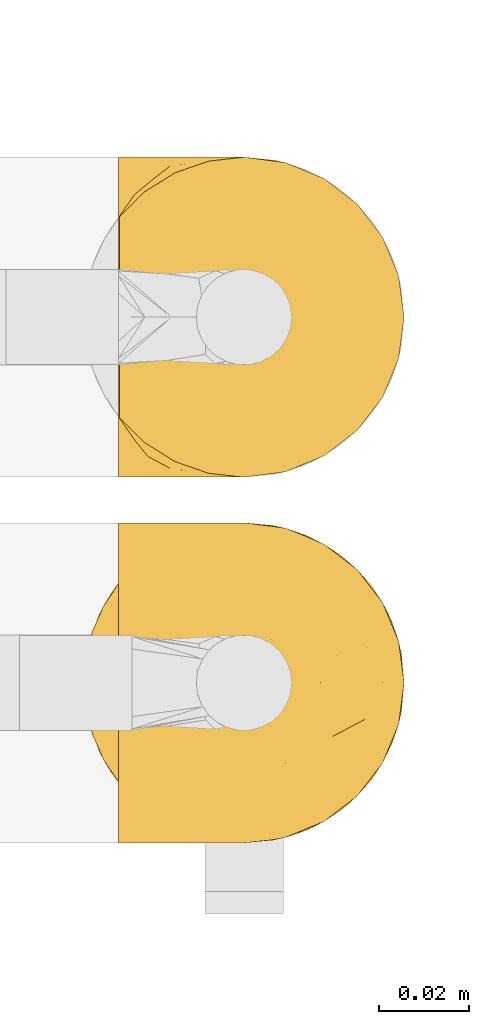
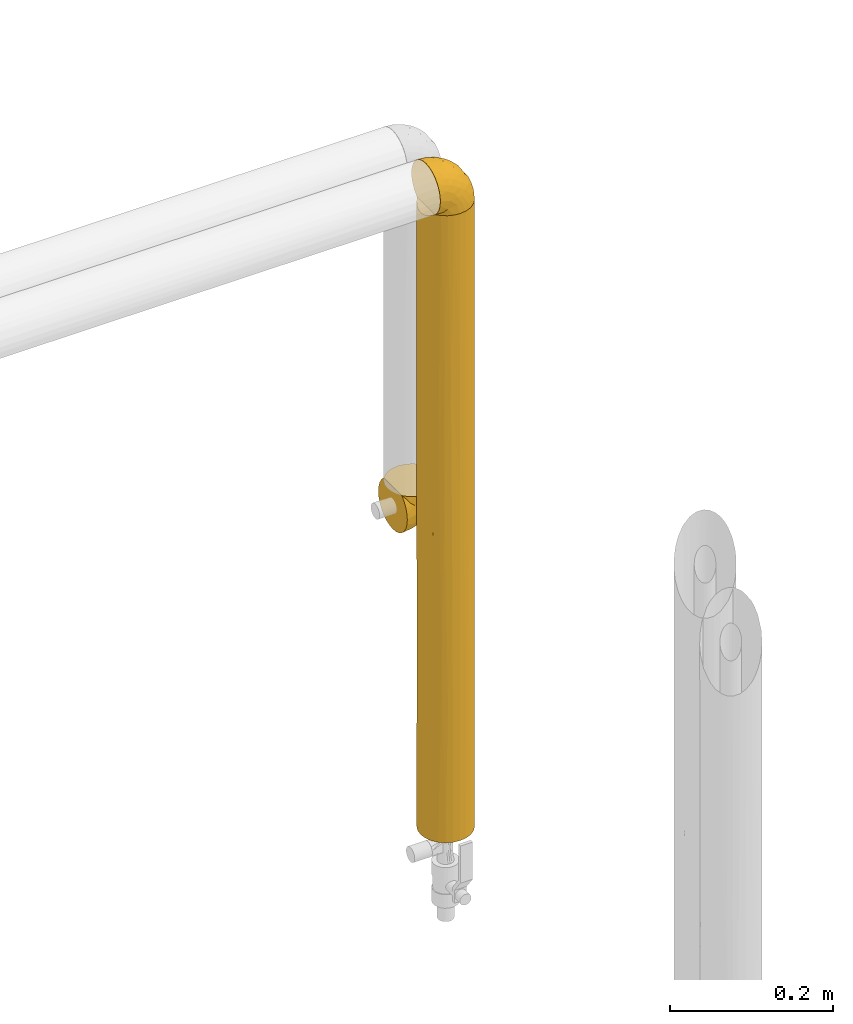
# One storey, part 94 of 827: 3 coverings.
"""IFC2X3 building model written with IfcOpenShell, lengths in millimetres."""

from ifc_helpers import new_model, entity, si_unit, converted_unit, derived_unit, direction, frame, origin, place, context, subcontext, project, spatial, faceted_brep, element, save


model = new_model("IFC2X3")

# Units and contexts
model_context = context("Model", 3, precision=0.01, world=origin(), true_north=direction((6.12303176911189e-17, 1.0)))
body_context = subcontext(model_context, "Body", "Model", "MODEL_VIEW")
ifc_project = project(units=[si_unit("LENGTHUNIT", "METRE", prefix="MILLI"), si_unit("AREAUNIT", "SQUARE_METRE"), si_unit("VOLUMEUNIT", "CUBIC_METRE"), converted_unit("PLANEANGLEUNIT", "DEGREE", entity("IfcRatioMeasure", 0.0174532925199433), si_unit("PLANEANGLEUNIT", "RADIAN"), dimensions=[0, 0, 0, 0, 0, 0, 0]), si_unit("MASSUNIT", "GRAM", prefix="KILO"), derived_unit("MASSDENSITYUNIT", [(si_unit("MASSUNIT", "GRAM", prefix="KILO"), 1), (si_unit("LENGTHUNIT", "METRE"), -3)]), derived_unit("MOMENTOFINERTIAUNIT", [(si_unit("LENGTHUNIT", "METRE"), 4)]), si_unit("TIMEUNIT", "SECOND"), si_unit("FREQUENCYUNIT", "HERTZ"), si_unit("THERMODYNAMICTEMPERATUREUNIT", "DEGREE_CELSIUS"), derived_unit("THERMALTRANSMITTANCEUNIT", [(si_unit("MASSUNIT", "GRAM", prefix="KILO"), 1), (si_unit("THERMODYNAMICTEMPERATUREUNIT", "KELVIN"), -1), (si_unit("TIMEUNIT", "SECOND"), -3)]), derived_unit("VOLUMETRICFLOWRATEUNIT", [(si_unit("LENGTHUNIT", "METRE"), 3), (si_unit("TIMEUNIT", "SECOND"), -1)]), derived_unit("MASSFLOWRATEUNIT", [(si_unit("MASSUNIT", "GRAM", prefix="KILO"), 1), (si_unit("TIMEUNIT", "SECOND"), -1)]), derived_unit("ROTATIONALFREQUENCYUNIT", [(si_unit("TIMEUNIT", "SECOND"), -1)]), si_unit("ELECTRICCURRENTUNIT", "AMPERE"), si_unit("ELECTRICVOLTAGEUNIT", "VOLT"), si_unit("POWERUNIT", "WATT"), si_unit("FORCEUNIT", "NEWTON", prefix="KILO"), si_unit("ILLUMINANCEUNIT", "LUX"), si_unit("LUMINOUSFLUXUNIT", "LUMEN"), si_unit("LUMINOUSINTENSITYUNIT", "CANDELA"), derived_unit("USERDEFINED", [(si_unit("MASSUNIT", "GRAM", prefix="KILO"), -1), (si_unit("LENGTHUNIT", "METRE"), -2), (si_unit("TIMEUNIT", "SECOND"), 3), (si_unit("LUMINOUSFLUXUNIT", "LUMEN"), 1)]), derived_unit("LINEARVELOCITYUNIT", [(si_unit("LENGTHUNIT", "METRE"), 1), (si_unit("TIMEUNIT", "SECOND"), -1)]), si_unit("PRESSUREUNIT", "PASCAL"), derived_unit("USERDEFINED", [(si_unit("LENGTHUNIT", "METRE"), -2), (si_unit("MASSUNIT", "GRAM", prefix="KILO"), 1), (si_unit("TIMEUNIT", "SECOND"), -2)]), derived_unit("LINEARFORCEUNIT", [(si_unit("MASSUNIT", "GRAM", prefix="KILO"), 1), (si_unit("LENGTHUNIT", "METRE"), 1), (si_unit("TIMEUNIT", "SECOND"), -2), (si_unit("LENGTHUNIT", "METRE"), -1)]), derived_unit("PLANARFORCEUNIT", [(si_unit("MASSUNIT", "GRAM", prefix="KILO"), 1), (si_unit("LENGTHUNIT", "METRE"), 1), (si_unit("TIMEUNIT", "SECOND"), -2), (si_unit("LENGTHUNIT", "METRE"), -2)])], contexts=[model_context])

# Site, building, storey
site_placement = place(None, origin())
site = spatial("IfcSite", under=ifc_project, at=site_placement, CompositionType="ELEMENT")
building_placement = place(site_placement, origin())
building = spatial("IfcBuilding", under=site, at=building_placement, CompositionType="ELEMENT")
storey_placement = place(building_placement, frame((0.0, 0.0, 28200.0)))
storey = spatial("IfcBuildingStorey", under=building, at=storey_placement, Name="08", CompositionType="ELEMENT", Elevation=28200.0)

# Coverings
covering_1_placement = place(storey_placement, frame((18854.98, 12899.2, 1335.46)))
element("IfcCovering", 1, at=covering_1_placement, inside=storey, Name=":ADSK_", ObjectType=":ADSK_", PredefinedType="INSULATION", context=body_context, shape_type="Brep", body=[
    faceted_brep([(1.6, 69.36, 21.77), (1.6, 65.11, 15.01), (1.6, 59.47, 9.37), (1.6, 52.71, 5.12), (1.6, 45.17, 2.49), (1.6, 37.25, 1.6), (1.6, 29.31, 2.49), (1.6, 21.77, 5.13), (1.6, 15.01, 9.38), (1.6, 9.37, 15.02), (1.6, 5.12, 21.78), (1.6, 2.49, 29.32), (1.6, 1.6, 37.25), (1.6, 2.48, 45.15), (1.6, 5.1, 52.65), (1.6, 9.31, 59.39), (1.6, 14.9, 65.02), (1.6, 16.96, 65.02), (1.6, 18.43, 65.02), (1.6, 20.19, 65.02), (1.6, 21.96, 65.02), (1.6, 23.72, 65.02), (1.6, 25.49, 65.02), (1.6, 27.25, 65.02), (1.6, 29.02, 65.02), (1.6, 30.78, 65.02), (1.6, 32.55, 65.02), (1.6, 34.31, 65.02), (1.6, 36.08, 65.02), (1.6, 37.84, 65.02), (1.6, 39.61, 65.02), (1.6, 41.37, 65.02), (1.6, 43.14, 65.02), (1.6, 45.19, 65.02), (1.6, 47.25, 65.02), (1.6, 49.31, 65.02), (1.6, 51.36, 65.02), (1.6, 53.42, 65.02), (1.6, 55.48, 65.02), (1.6, 57.53, 65.02), (1.6, 59.59, 65.02), (1.6, 65.19, 59.38), (1.6, 69.4, 52.64), (1.6, 72.01, 45.13), (1.6, 72.9, 37.25), (1.6, 72.0, 29.31), (1.82, 14.9, 65.25), (7.46, 9.3, 65.25), (14.2, 5.09, 65.25), (21.7, 2.48, 65.25), (29.6, 1.6, 65.25), (38.82, 2.81, 65.25), (47.42, 6.37, 65.25), (54.8, 12.04, 65.25), (60.47, 19.42, 65.25), (64.03, 28.02, 65.25), (65.25, 37.25, 65.25), (64.03, 46.47, 65.25), (60.47, 55.07, 65.25), (54.8, 62.45, 65.25), (47.42, 68.12, 65.25), (38.82, 71.68, 65.25), (29.6, 72.9, 65.25), (21.7, 72.01, 65.25), (14.2, 69.4, 65.25), (7.46, 65.19, 65.25), (1.82, 59.59, 65.25), (1.82, 58.56, 65.25), (1.82, 56.8, 65.25), (1.82, 55.4, 65.25), (1.82, 54.0, 65.25), (1.82, 52.61, 65.25), (1.82, 51.21, 65.25), (1.82, 49.81, 65.25), (1.82, 48.42, 65.25), (1.82, 47.02, 65.25), (1.82, 45.62, 65.25), (1.82, 44.23, 65.25), (1.82, 42.83, 65.25), (1.82, 41.43, 65.25), (1.82, 40.04, 65.25), (1.82, 38.64, 65.25), (1.82, 37.25, 65.25), (1.82, 35.48, 65.25), (1.82, 33.72, 65.25), (1.82, 31.95, 65.25), (1.82, 30.19, 65.25), (1.82, 28.42, 65.25), (1.82, 26.66, 65.25), (1.82, 24.89, 65.25), (1.82, 23.13, 65.25), (1.82, 21.07, 65.25), (1.82, 19.01, 65.25), (1.82, 16.96, 65.25), (1.75, 50.36, 65.08), (1.76, 51.91, 65.09), (1.76, 27.73, 65.09), (1.76, 29.06, 65.1), (1.74, 23.0, 65.08), (1.76, 39.29, 65.09), (1.75, 16.3, 65.09), (1.75, 17.69, 65.09), (1.75, 42.09, 65.09), (1.76, 43.53, 65.1), (1.74, 58.23, 65.08), (1.75, 59.59, 65.09), (1.74, 46.32, 65.08), (1.76, 47.68, 65.09), (1.75, 19.0, 65.08), (1.75, 30.39, 65.09), (1.74, 31.67, 65.07), (1.76, 37.94, 65.1), (1.76, 36.57, 65.09), (1.76, 45.01, 65.1), (1.73, 35.19, 65.07), (1.74, 26.37, 65.07), (1.75, 25.1, 65.09), (1.74, 56.91, 65.08), (1.75, 40.68, 65.09), (1.78, 32.77, 65.13), (1.76, 20.34, 65.1), (1.76, 21.67, 65.09), (1.75, 33.92, 65.09), (1.76, 53.39, 65.1), (1.75, 54.7, 65.09), (1.75, 14.9, 65.09), (1.76, 49.03, 65.09), (13.11, 3.58, 53.74), (8.18, 6.24, 57.19), (25.84, 1.6, 51.25), (28.13, 1.6, 59.77), (15.6, 1.6, 41.0), (5.2, 9.92, 61.64), (20.72, 1.6, 46.12), (7.07, 1.6, 38.71), (35.56, 27.59, 13.0), (16.98, 25.47, 5.55), (25.95, 37.25, 6.44), (35.4, 2.33, 55.39), (32.74, 2.37, 48.48), (43.51, 8.53, 39.63), (53.51, 15.54, 43.5), (49.6, 8.96, 52.38), (40.07, 4.31, 49.31), (42.61, 4.31, 58.01), (20.45, 7.06, 22.23), (10.52, 7.06, 19.14), (14.87, 12.03, 13.73), (24.92, 2.3, 39.1), (34.61, 21.13, 15.38), (61.84, 30.63, 46.7), (60.43, 23.6, 49.4), (14.29, 37.25, 4.12), (57.0, 15.54, 55.35), (42.79, 18.65, 23.83), (33.34, 15.3, 19.0), (21.53, 3.14, 32.44), (11.52, 3.59, 26.73), (12.66, 18.27, 8.12), (34.11, 7.07, 31.34), (32.29, 3.86, 38.81), (24.41, 13.04, 16.11), (24.95, 18.27, 11.96), (44.19, 26.27, 20.31), (56.24, 23.06, 38.81), (56.83, 29.25, 35.48), (50.94, 24.41, 28.94), (50.38, 31.04, 25.21), (46.6, 37.25, 20.24), (36.28, 37.25, 13.34), (62.72, 37.25, 52.55), (47.39, 15.08, 33.16), (38.92, 12.03, 27.33), (29.55, 9.82, 22.86), (26.82, 6.14, 27.48), (60.4, 37.25, 40.89), (53.5, 37.25, 30.56), (41.8, 70.18, 54.41), (61.8, 44.04, 46.71), (49.33, 49.17, 26.31), (35.54, 46.9, 12.98), (14.87, 62.45, 13.72), (12.65, 56.21, 8.12), (47.44, 65.53, 46.04), (56.06, 58.95, 51.06), (50.17, 58.17, 35.69), (20.44, 67.43, 22.22), (10.52, 67.43, 19.13), (11.52, 70.89, 26.72), (38.79, 55.13, 19.65), (33.87, 72.21, 51.87), (25.84, 72.9, 51.25), (27.72, 72.9, 58.25), (7.07, 72.9, 38.71), (62.13, 49.42, 54.36), (50.52, 65.53, 56.5), (56.47, 45.41, 34.9), (58.39, 50.89, 43.16), (16.98, 49.01, 5.54), (39.3, 66.8, 35.66), (38.56, 70.39, 47.21), (24.94, 56.21, 11.95), (30.34, 72.31, 46.27), (26.49, 72.1, 39.95), (15.6, 72.9, 41.0), (20.72, 72.9, 46.12), (26.6, 62.45, 18.27), (21.54, 71.35, 32.43), (35.7, 72.26, 58.69), (38.91, 62.45, 27.31), (30.65, 67.99, 29.52), (44.9, 62.85, 35.02), (34.09, 70.57, 40.81), (13.11, 70.91, 53.74), (9.65, 68.25, 58.66), (5.2, 64.57, 61.64)], [[[0, 1, 2, 3, 4, 5, 6, 7, 8, 9, 10, 11, 12, 13, 14, 15, 16, 17, 18, 19, 20, 21, 22, 23, 24, 25, 26, 27, 28, 29, 30, 31, 32, 33, 34, 35, 36, 37, 38, 39, 40, 41, 42, 43, 44, 45]], [[46, 47, 48, 49, 50, 51, 52, 53, 54, 55, 56, 57, 58, 59, 60, 61, 62, 63, 64, 65, 66, 67, 68, 69, 70, 71, 72, 73, 74, 75, 76, 77, 78, 79, 80, 81, 82, 83, 84, 85, 86, 87, 88, 89, 90, 91, 92, 93]], [[94, 72, 95]], [[96, 87, 97]], [[20, 98, 21]], [[99, 81, 80]], [[100, 93, 101]], [[102, 103, 32]], [[104, 105, 40]], [[67, 105, 104]], [[106, 107, 34]], [[18, 101, 108]], [[109, 85, 110]], [[36, 94, 95]], [[81, 111, 82]], [[29, 28, 112]], [[17, 101, 18]], [[103, 113, 33]], [[24, 96, 97]], [[28, 114, 112]], [[115, 22, 116]], [[31, 102, 32]], [[68, 104, 117]], [[31, 118, 102]], [[84, 119, 85]], [[120, 91, 121]], [[23, 22, 115]], [[114, 27, 122]], [[123, 37, 95]], [[117, 124, 69]], [[67, 66, 105]], [[104, 39, 117]], [[123, 124, 37]], [[100, 17, 16]], [[100, 125, 46]], [[17, 100, 101]], [[107, 126, 35]], [[92, 108, 101]], [[115, 88, 96]], [[114, 122, 83]], [[101, 93, 92]], [[93, 100, 46]], [[16, 125, 100]], [[108, 19, 18]], [[120, 121, 19]], [[108, 92, 120]], [[19, 108, 120]], [[67, 104, 68]], [[39, 104, 40]], [[69, 68, 117]], [[117, 39, 38]], [[70, 124, 123]], [[124, 70, 69]], [[38, 124, 117]], [[124, 38, 37]], [[72, 71, 95]], [[71, 123, 95]], [[71, 70, 123]], [[126, 94, 35]], [[37, 36, 95]], [[75, 74, 107]], [[73, 72, 94]], [[94, 36, 35]], [[94, 126, 73]], [[74, 73, 126]], [[106, 76, 75]], [[76, 106, 113]], [[113, 106, 33]], [[107, 35, 34]], [[106, 34, 33]], [[126, 107, 74]], [[107, 106, 75]], [[78, 77, 103]], [[77, 113, 103]], [[77, 76, 113]], [[102, 78, 103]], [[33, 32, 103]], [[80, 79, 118]], [[102, 118, 79]], [[112, 111, 29]], [[118, 31, 30]], [[79, 78, 102]], [[99, 111, 81]], [[112, 82, 111]], [[111, 99, 29]], [[30, 29, 99]], [[112, 83, 82]], [[27, 114, 28]], [[99, 118, 30]], [[118, 99, 80]], [[114, 83, 112]], [[84, 83, 122]], [[109, 110, 25]], [[122, 27, 26]], [[119, 110, 85]], [[20, 19, 121]], [[25, 110, 26]], [[91, 120, 92]], [[90, 98, 121]], [[121, 91, 90]], [[23, 115, 96]], [[88, 115, 116]], [[116, 98, 89]], [[89, 88, 116]], [[23, 96, 24]], [[87, 96, 88]], [[25, 24, 109]], [[97, 87, 86]], [[90, 89, 98]], [[116, 22, 21]], [[122, 26, 119]], [[86, 85, 109]], [[109, 97, 86]], [[97, 109, 24]], [[110, 119, 26]], [[122, 119, 84]], [[121, 98, 20]], [[21, 98, 116]], [[48, 127, 49]], [[48, 47, 128]], [[49, 129, 130, 50]], [[129, 49, 127]], [[131, 127, 13]], [[46, 125, 132]], [[16, 15, 132]], [[127, 128, 14]], [[127, 131, 133, 129]], [[14, 13, 127]], [[13, 12, 134, 131]], [[46, 132, 47]], [[48, 128, 127]], [[47, 132, 128]], [[15, 128, 132]], [[125, 16, 132]], [[15, 14, 128]], [[135, 136, 137]], [[138, 129, 139]], [[140, 141, 142]], [[143, 144, 138]], [[145, 146, 147]], [[133, 148, 139]], [[134, 12, 11]], [[136, 135, 149]], [[150, 55, 151]], [[136, 6, 152]], [[153, 54, 53]], [[52, 144, 142]], [[52, 142, 53]], [[54, 153, 151]], [[144, 52, 51]], [[154, 155, 149]], [[156, 131, 157]], [[134, 11, 157]], [[8, 7, 158]], [[147, 9, 8]], [[157, 131, 134]], [[157, 11, 10]], [[146, 157, 10]], [[159, 140, 160]], [[157, 145, 156]], [[161, 162, 155]], [[161, 147, 162]], [[154, 149, 163]], [[150, 164, 165]], [[136, 7, 6]], [[137, 136, 152]], [[162, 158, 136]], [[54, 151, 55]], [[158, 147, 8]], [[166, 167, 165]], [[9, 146, 10]], [[164, 166, 165]], [[168, 135, 137, 169]], [[55, 150, 170]], [[154, 171, 172]], [[139, 148, 160]], [[140, 142, 143]], [[153, 142, 141]], [[51, 50, 130]], [[145, 173, 174]], [[156, 160, 148]], [[6, 5, 152]], [[136, 158, 7]], [[147, 158, 162]], [[147, 146, 9]], [[157, 146, 145]], [[160, 140, 143]], [[140, 172, 171]], [[139, 143, 138]], [[173, 159, 174]], [[170, 150, 175]], [[170, 56, 55]], [[167, 168, 176]], [[176, 175, 165]], [[150, 165, 175]], [[163, 167, 166]], [[176, 165, 167]], [[164, 150, 151]], [[151, 141, 164]], [[171, 164, 141]], [[154, 163, 166]], [[163, 135, 168]], [[166, 164, 171]], [[155, 154, 172]], [[166, 171, 154]], [[140, 171, 141]], [[173, 155, 172]], [[149, 155, 162]], [[159, 173, 172]], [[161, 145, 147]], [[140, 159, 172]], [[174, 160, 156]], [[136, 149, 162]], [[149, 135, 163]], [[155, 173, 161]], [[145, 161, 173]], [[160, 174, 159]], [[156, 148, 131]], [[156, 145, 174]], [[142, 153, 53]], [[151, 153, 141]], [[138, 51, 130]], [[142, 144, 143]], [[51, 138, 144]], [[129, 138, 130]], [[133, 139, 129]], [[160, 143, 139]], [[168, 167, 163]], [[131, 148, 133]], [[60, 177, 61]], [[175, 178, 170]], [[179, 168, 180]], [[178, 57, 170]], [[181, 182, 2]], [[183, 184, 185]], [[186, 187, 188]], [[189, 185, 179]], [[190, 191, 192]], [[45, 193, 188]], [[194, 184, 58]], [[45, 44, 193]], [[59, 195, 60]], [[60, 195, 177]], [[0, 45, 188]], [[196, 179, 197]], [[180, 137, 198]], [[183, 199, 200]], [[201, 182, 181]], [[1, 181, 2]], [[57, 178, 194]], [[198, 3, 182]], [[198, 152, 4]], [[1, 0, 187]], [[190, 202, 191]], [[203, 204, 205]], [[206, 201, 181]], [[186, 188, 207]], [[188, 204, 207]], [[3, 198, 4]], [[58, 184, 59]], [[187, 181, 1]], [[180, 198, 201]], [[206, 181, 186]], [[180, 189, 179]], [[3, 2, 182]], [[180, 168, 169, 137]], [[204, 188, 193]], [[177, 190, 208]], [[209, 210, 199]], [[210, 186, 207]], [[185, 184, 197]], [[195, 184, 183]], [[205, 202, 203]], [[210, 209, 206]], [[179, 185, 197]], [[211, 209, 199]], [[196, 197, 178]], [[180, 201, 189]], [[152, 198, 137]], [[152, 5, 4]], [[61, 208, 62]], [[198, 182, 201]], [[188, 187, 0]], [[181, 187, 186]], [[203, 210, 207]], [[202, 205, 191]], [[199, 210, 212]], [[57, 56, 170]], [[176, 196, 175]], [[178, 197, 194]], [[179, 176, 168]], [[175, 196, 178]], [[176, 179, 196]], [[184, 194, 197]], [[58, 57, 194]], [[208, 190, 192]], [[200, 190, 177]], [[206, 189, 201]], [[185, 189, 209]], [[62, 208, 192]], [[177, 208, 61]], [[210, 206, 186]], [[189, 206, 209]], [[200, 199, 212]], [[211, 183, 185]], [[184, 195, 59]], [[177, 195, 183]], [[183, 200, 177]], [[202, 200, 212]], [[200, 202, 190]], [[202, 212, 203]], [[210, 203, 212]], [[204, 203, 207]], [[183, 211, 199]], [[185, 209, 211]], [[63, 62, 192, 191]], [[64, 63, 213]], [[64, 213, 214]], [[65, 215, 66]], [[213, 191, 205, 204]], [[43, 204, 193, 44]], [[65, 214, 215]], [[42, 213, 43]], [[215, 105, 66]], [[41, 214, 42]], [[40, 105, 215]], [[65, 64, 214]], [[40, 215, 41]], [[213, 63, 191]], [[42, 214, 213]], [[204, 43, 213]], [[214, 41, 215]]]),
])
covering_2_placement = place(storey_placement, frame((18847.33, 12817.76, 930.45)))
element("IfcCovering", 2, at=covering_2_placement, inside=storey, Name=":ADSK_", ObjectType=":ADSK_", PredefinedType="INSULATION", context=body_context, shape_type="Brep", body=[
    faceted_brep([(12.04, 12.04, 0.0), (6.37, 19.42, 0.0), (2.81, 28.02, 0.0), (1.6, 37.25, 0.0), (2.81, 46.47, 0.0), (6.37, 55.07, 0.0), (12.04, 62.45, 0.0), (19.42, 68.12, 0.0), (28.02, 71.68, 0.0), (37.25, 72.9, 0.0), (46.47, 71.68, 0.0), (55.07, 68.12, 0.0), (62.45, 62.45, 0.0), (68.12, 55.07, 0.0), (71.68, 46.47, 0.0), (72.9, 37.25, 0.0), (71.68, 28.02, 0.0), (68.12, 19.42, 0.0), (62.45, 12.04, 0.0), (55.07, 6.37, 0.0), (46.47, 2.81, 0.0), (37.25, 1.6, 0.0), (28.02, 2.81, 0.0), (19.42, 6.37, 0.0), (9.25, 15.18, 941.55), (14.89, 9.47, 941.55), (21.68, 5.17, 941.55), (29.26, 2.5, 941.55), (37.25, 1.6, 941.55), (46.47, 2.81, 941.55), (55.07, 6.37, 941.55), (62.45, 12.04, 941.55), (68.12, 19.42, 941.55), (71.68, 28.02, 941.55), (72.9, 37.25, 941.55), (71.68, 46.47, 941.55), (68.12, 55.07, 941.55), (62.45, 62.45, 941.55), (55.07, 68.12, 941.55), (46.47, 71.68, 941.55), (37.25, 72.9, 941.55), (29.26, 71.99, 941.55), (21.68, 69.32, 941.55), (14.89, 65.02, 941.55), (9.25, 59.31, 941.55), (18.17, 7.13, 751.57), (25.39, 3.62, 686.37), (8.96, 15.54, 220.7), (7.59, 17.46, 713.41), (12.07, 12.0, 596.17), (1.6, 37.25, 258.47), (37.25, 1.6, 733.07), (7.68, 17.33, 471.23), (15.54, 8.96, 255.44), (37.25, 1.6, 262.3), (27.27, 3.02, 353.02), (37.25, 1.6, 524.59), (5.97, 20.14, 938.28), (3.56, 25.57, 935.87), (2.73, 28.33, 654.29), (2.79, 28.1, 327.18), (1.6, 37.25, 516.94), (21.91, 5.06, 205.87), (4.98, 22.09, 204.18), (2.09, 31.32, 934.4), (1.6, 37.25, 725.42), (18.17, 7.13, 528.99), (1.6, 37.25, 933.9), (37.25, 1.6, 208.48), (3.56, 48.92, 935.87), (7.59, 57.03, 713.41), (2.73, 46.16, 654.29), (2.09, 43.17, 934.4), (8.96, 58.95, 220.7), (2.79, 46.39, 327.18), (4.98, 52.4, 204.18), (5.97, 54.35, 938.28), (7.68, 57.16, 471.23), (12.07, 62.49, 596.17), (18.17, 67.36, 751.57), (27.27, 71.47, 353.02), (37.25, 72.9, 262.3), (25.39, 70.87, 686.37), (37.25, 72.9, 208.48), (18.17, 67.36, 528.99), (37.25, 72.9, 524.59), (37.25, 72.9, 416.96), (20.79, 68.87, 347.25), (15.54, 65.53, 255.44), (37.25, 72.9, 733.07), (37.25, 72.9, 679.26), (58.95, 65.53, 725.37), (50.89, 70.18, 648.55), (58.95, 65.53, 216.18), (65.53, 58.95, 267.88), (64.04, 60.76, 458.21), (70.18, 50.89, 400.19), (50.89, 70.18, 293.01), (58.95, 65.53, 470.78), (43.95, 72.26, 545.72), (43.76, 72.3, 312.72), (65.53, 58.95, 648.55), (72.26, 43.97, 628.83), (72.9, 37.25, 524.59), (72.31, 43.66, 411.25), (43.88, 72.27, 751.04), (69.05, 53.36, 219.81), (71.53, 47.01, 217.26), (72.9, 37.25, 733.07), (72.9, 37.25, 679.26), (72.9, 37.25, 208.48), (70.18, 50.89, 702.47), (72.9, 37.25, 416.96), (65.53, 15.54, 725.37), (70.18, 23.6, 648.55), (65.53, 15.54, 216.18), (58.95, 8.96, 267.88), (60.76, 10.45, 458.21), (50.89, 4.31, 400.19), (70.18, 23.6, 293.01), (65.53, 15.54, 470.78), (72.26, 30.54, 545.72), (72.3, 30.73, 312.72), (58.95, 8.96, 648.55), (43.97, 2.24, 628.83), (43.66, 2.18, 411.25), (72.27, 30.61, 751.04), (53.36, 5.44, 219.81), (47.01, 2.96, 217.26), (50.89, 4.31, 702.47)], [[[0, 1, 2, 3, 4, 5, 6, 7, 8, 9, 10, 11, 12, 13, 14, 15, 16, 17, 18, 19, 20, 21, 22, 23]], [[24, 25, 26, 27, 28, 29, 30, 31, 32, 33, 34, 35, 36, 37, 38, 39, 40, 41, 42, 43, 44]], [[45, 46, 26]], [[0, 47, 1]], [[24, 48, 49]], [[26, 46, 27]], [[2, 50, 3]], [[25, 45, 26]], [[46, 51, 27]], [[52, 47, 53]], [[49, 48, 52]], [[22, 54, 55]], [[55, 56, 46]], [[48, 57, 58]], [[49, 25, 24]], [[59, 52, 48]], [[24, 57, 48]], [[60, 59, 61]], [[50, 2, 60]], [[48, 58, 59]], [[22, 55, 62]], [[46, 56, 51]], [[51, 28, 27]], [[1, 47, 63]], [[60, 61, 50]], [[64, 65, 59]], [[58, 64, 59]], [[66, 53, 62]], [[63, 2, 1]], [[53, 0, 23]], [[52, 59, 60]], [[55, 46, 66]], [[62, 53, 23]], [[53, 66, 49]], [[53, 49, 52]], [[49, 66, 45]], [[53, 47, 0]], [[63, 52, 60]], [[49, 45, 25]], [[46, 45, 66]], [[52, 63, 47]], [[2, 63, 60]], [[65, 64, 67]], [[65, 61, 59]], [[22, 21, 68, 54]], [[54, 56, 55]], [[22, 62, 23]], [[66, 62, 55]], [[69, 70, 71]], [[72, 69, 71]], [[73, 6, 5]], [[4, 74, 75]], [[67, 72, 65]], [[70, 76, 44]], [[72, 71, 65]], [[77, 73, 75]], [[70, 78, 77]], [[78, 43, 79]], [[4, 50, 74]], [[80, 81, 8]], [[74, 61, 71]], [[71, 77, 74]], [[42, 41, 82]], [[8, 81, 83, 9]], [[79, 82, 84]], [[80, 85, 86, 81]], [[80, 82, 85]], [[87, 7, 88]], [[70, 69, 76]], [[41, 89, 82]], [[44, 43, 78]], [[88, 77, 78]], [[82, 80, 84]], [[84, 80, 87]], [[71, 70, 77]], [[79, 43, 42]], [[87, 8, 7]], [[6, 88, 7]], [[88, 6, 73]], [[87, 88, 84]], [[78, 70, 44]], [[88, 78, 84]], [[75, 73, 5]], [[88, 73, 77]], [[82, 79, 42]], [[78, 79, 84]], [[4, 75, 5]], [[77, 75, 74]], [[71, 61, 65]], [[89, 41, 40]], [[82, 89, 90, 85]], [[50, 4, 3]], [[50, 61, 74]], [[87, 80, 8]], [[91, 92, 38]], [[93, 94, 12]], [[95, 96, 94]], [[93, 97, 92, 91, 98]], [[38, 92, 39]], [[99, 92, 97]], [[37, 91, 38]], [[100, 83, 81, 86]], [[93, 12, 11]], [[11, 10, 97]], [[36, 101, 37]], [[101, 95, 98]], [[102, 103, 104]], [[105, 92, 99]], [[96, 106, 94]], [[107, 106, 96]], [[94, 13, 12]], [[98, 91, 101]], [[102, 108, 109, 103]], [[15, 14, 110]], [[35, 34, 108]], [[111, 101, 36]], [[10, 83, 100]], [[97, 100, 99]], [[111, 36, 35]], [[104, 107, 96]], [[108, 102, 35]], [[104, 96, 102]], [[39, 105, 40]], [[96, 101, 111]], [[97, 93, 11]], [[93, 98, 95]], [[101, 91, 37]], [[10, 9, 83]], [[100, 86, 99]], [[10, 100, 97]], [[99, 86, 85, 90]], [[105, 99, 90]], [[96, 111, 102]], [[35, 102, 111]], [[104, 103, 112, 110]], [[107, 110, 14]], [[110, 107, 104]], [[106, 14, 13]], [[14, 106, 107]], [[13, 94, 106]], [[105, 90, 89, 40]], [[92, 105, 39]], [[96, 95, 101]], [[93, 95, 94]], [[113, 114, 32]], [[115, 116, 18]], [[117, 118, 116]], [[115, 119, 114, 113, 120]], [[32, 114, 33]], [[121, 114, 119]], [[31, 113, 32]], [[112, 122, 110]], [[115, 18, 17]], [[17, 16, 119]], [[30, 123, 31]], [[123, 117, 120]], [[124, 56, 125]], [[126, 114, 121]], [[118, 127, 116]], [[128, 127, 118]], [[116, 19, 18]], [[120, 113, 123]], [[56, 124, 51]], [[21, 20, 68]], [[29, 28, 51]], [[129, 123, 30]], [[16, 110, 122]], [[119, 122, 121]], [[129, 30, 29]], [[125, 128, 118]], [[51, 124, 29]], [[125, 118, 124]], [[33, 126, 34]], [[118, 123, 129]], [[119, 115, 17]], [[115, 120, 117]], [[123, 113, 31]], [[16, 15, 110]], [[122, 112, 121]], [[16, 122, 119]], [[121, 112, 103, 109]], [[126, 121, 109]], [[118, 129, 124]], [[29, 124, 129]], [[125, 56, 54, 68]], [[128, 68, 20]], [[68, 128, 125]], [[127, 20, 19]], [[20, 127, 128]], [[19, 116, 127]], [[126, 109, 108, 34]], [[114, 126, 33]], [[118, 117, 123]], [[115, 117, 116]], [[64, 58, 57, 24, 44, 76, 69, 72, 67]]]),
])
covering_3_placement = place(storey_placement, frame((18854.98, 12817.76, 1870.4)))
element("IfcCovering", 3, at=covering_3_placement, inside=storey, Name=":ADSK_", ObjectType=":ADSK_", PredefinedType="INSULATION", context=body_context, shape_type="Brep", body=[
    faceted_brep([(1.6, 5.13, 45.07), (1.6, 9.38, 51.83), (1.6, 15.02, 57.47), (1.6, 21.78, 61.72), (1.6, 29.32, 64.35), (1.6, 37.25, 65.25), (1.6, 45.18, 64.35), (1.6, 52.72, 61.71), (1.6, 59.48, 57.46), (1.6, 65.12, 51.82), (1.6, 69.37, 45.06), (1.6, 72.0, 37.52), (1.6, 72.9, 29.6), (1.6, 72.01, 21.69), (1.6, 69.39, 14.19), (1.6, 65.18, 7.45), (1.6, 59.59, 1.82), (1.6, 57.53, 1.82), (1.6, 56.06, 1.82), (1.6, 54.3, 1.82), (1.6, 52.53, 1.82), (1.6, 50.77, 1.82), (1.6, 49.0, 1.82), (1.6, 47.24, 1.82), (1.6, 45.47, 1.82), (1.6, 43.71, 1.82), (1.6, 41.94, 1.82), (1.6, 40.18, 1.82), (1.6, 38.41, 1.82), (1.6, 36.65, 1.82), (1.6, 34.88, 1.82), (1.6, 33.12, 1.82), (1.6, 31.35, 1.82), (1.6, 29.3, 1.82), (1.6, 27.24, 1.82), (1.6, 25.18, 1.82), (1.6, 23.13, 1.82), (1.6, 21.07, 1.82), (1.6, 19.01, 1.82), (1.6, 16.96, 1.82), (1.6, 14.9, 1.82), (1.6, 9.3, 7.46), (1.6, 5.09, 14.2), (1.6, 2.48, 21.71), (1.6, 1.6, 29.6), (1.6, 2.49, 37.53), (1.82, 59.59, 1.6), (7.46, 65.19, 1.6), (14.2, 69.4, 1.6), (21.7, 72.01, 1.6), (29.6, 72.9, 1.6), (38.82, 71.68, 1.6), (47.42, 68.12, 1.6), (54.8, 62.45, 1.6), (60.47, 55.07, 1.6), (64.03, 46.47, 1.6), (65.25, 37.25, 1.6), (64.03, 28.02, 1.6), (60.47, 19.42, 1.6), (54.8, 12.04, 1.6), (47.42, 6.37, 1.6), (38.82, 2.81, 1.6), (29.6, 1.6, 1.6), (21.7, 2.48, 1.6), (14.2, 5.09, 1.6), (7.46, 9.3, 1.6), (1.82, 14.9, 1.6), (1.82, 15.93, 1.6), (1.82, 17.69, 1.6), (1.82, 19.09, 1.6), (1.82, 20.49, 1.6), (1.82, 21.88, 1.6), (1.82, 23.28, 1.6), (1.82, 24.68, 1.6), (1.82, 26.07, 1.6), (1.82, 27.47, 1.6), (1.82, 28.87, 1.6), (1.82, 30.26, 1.6), (1.82, 31.66, 1.6), (1.82, 33.06, 1.6), (1.82, 34.45, 1.6), (1.82, 35.85, 1.6), (1.82, 37.25, 1.6), (1.82, 39.01, 1.6), (1.82, 40.77, 1.6), (1.82, 42.54, 1.6), (1.82, 44.3, 1.6), (1.82, 46.07, 1.6), (1.82, 47.83, 1.6), (1.82, 49.6, 1.6), (1.82, 51.36, 1.6), (1.82, 53.42, 1.6), (1.82, 55.48, 1.6), (1.82, 57.53, 1.6), (1.75, 24.13, 1.76), (1.76, 22.58, 1.75), (1.76, 46.76, 1.75), (1.76, 45.43, 1.74), (1.74, 51.49, 1.76), (1.76, 35.2, 1.75), (1.75, 58.19, 1.75), (1.75, 56.8, 1.75), (1.75, 32.4, 1.75), (1.76, 30.96, 1.75), (1.74, 16.26, 1.76), (1.75, 14.9, 1.75), (1.74, 28.17, 1.76), (1.76, 26.81, 1.75), (1.75, 55.49, 1.76), (1.75, 44.1, 1.75), (1.74, 42.83, 1.77), (1.76, 36.55, 1.74), (1.76, 37.92, 1.75), (1.76, 29.48, 1.75), (1.73, 39.3, 1.77), (1.74, 48.12, 1.77), (1.75, 49.39, 1.75), (1.74, 17.58, 1.76), (1.75, 33.81, 1.75), (1.78, 41.72, 1.71), (1.76, 54.15, 1.74), (1.76, 52.82, 1.75), (1.75, 40.57, 1.75), (1.76, 21.1, 1.74), (1.75, 19.79, 1.75), (1.75, 59.59, 1.75), (1.76, 25.46, 1.75), (13.11, 70.91, 13.1), (8.18, 68.25, 9.65), (25.84, 72.9, 15.6), (28.13, 72.9, 7.07), (15.6, 72.9, 25.84), (5.2, 64.57, 5.2), (20.72, 72.9, 20.72), (7.07, 72.9, 28.13), (35.56, 46.9, 53.84), (16.98, 49.02, 61.29), (25.95, 37.25, 60.4), (35.4, 72.16, 11.45), (32.74, 72.12, 18.37), (43.51, 65.96, 27.21), (53.51, 58.95, 23.34), (49.6, 65.53, 14.46), (40.07, 70.18, 17.53), (42.61, 70.18, 8.83), (20.45, 67.43, 44.61), (10.52, 67.43, 47.7), (14.87, 62.46, 53.12), (24.92, 72.19, 27.74), (34.61, 53.36, 51.46), (61.84, 43.86, 20.14), (60.43, 50.89, 17.44), (14.29, 37.25, 62.72), (57.0, 58.95, 11.49), (42.79, 55.84, 43.01), (33.34, 59.19, 47.84), (21.53, 71.35, 34.4), (11.52, 70.9, 40.11), (12.66, 56.22, 58.72), (34.11, 67.42, 35.5), (32.29, 70.63, 28.03), (24.41, 61.45, 50.73), (24.95, 56.22, 54.88), (44.19, 48.22, 46.53), (56.24, 51.43, 28.03), (56.83, 45.24, 31.36), (50.94, 50.08, 37.9), (50.38, 43.45, 41.63), (46.6, 37.25, 46.6), (36.28, 37.25, 53.5), (62.72, 37.25, 14.29), (47.39, 59.41, 33.68), (38.92, 62.46, 39.51), (29.55, 64.67, 43.98), (26.82, 68.35, 39.36), (60.4, 37.25, 25.95), (53.5, 37.25, 36.28), (41.8, 4.31, 12.43), (61.8, 30.45, 20.13), (49.33, 25.32, 40.53), (35.54, 27.59, 53.86), (14.87, 12.04, 53.13), (12.65, 18.28, 58.72), (47.44, 8.96, 20.81), (56.06, 15.54, 15.78), (50.17, 16.32, 31.15), (20.44, 7.06, 44.62), (10.52, 7.06, 47.71), (11.52, 3.6, 40.12), (38.79, 19.36, 47.19), (33.87, 2.28, 14.97), (25.84, 1.6, 15.6), (27.72, 1.6, 8.6), (7.07, 1.6, 28.13), (62.13, 25.07, 12.48), (50.52, 8.96, 10.34), (56.47, 29.08, 31.94), (58.39, 23.6, 23.68), (16.98, 25.48, 61.3), (39.3, 7.69, 31.18), (38.56, 4.1, 19.63), (24.94, 18.28, 54.89), (30.34, 2.18, 20.57), (26.49, 2.39, 26.89), (15.6, 1.6, 25.84), (20.72, 1.6, 20.72), (26.6, 12.04, 48.57), (21.54, 3.15, 34.41), (35.7, 2.24, 8.15), (38.91, 12.04, 39.53), (30.65, 6.5, 37.32), (44.9, 11.64, 31.82), (34.09, 3.92, 26.03), (13.11, 3.58, 13.1), (9.65, 6.24, 8.18), (5.2, 9.92, 5.2)], [[[0, 1, 2, 3, 4, 5, 6, 7, 8, 9, 10, 11, 12, 13, 14, 15, 16, 17, 18, 19, 20, 21, 22, 23, 24, 25, 26, 27, 28, 29, 30, 31, 32, 33, 34, 35, 36, 37, 38, 39, 40, 41, 42, 43, 44, 45]], [[46, 47, 48, 49, 50, 51, 52, 53, 54, 55, 56, 57, 58, 59, 60, 61, 62, 63, 64, 65, 66, 67, 68, 69, 70, 71, 72, 73, 74, 75, 76, 77, 78, 79, 80, 81, 82, 83, 84, 85, 86, 87, 88, 89, 90, 91, 92, 93]], [[94, 72, 95]], [[96, 87, 97]], [[20, 98, 21]], [[99, 81, 80]], [[100, 93, 101]], [[102, 103, 32]], [[104, 105, 40]], [[67, 105, 104]], [[106, 107, 34]], [[18, 101, 108]], [[109, 85, 110]], [[36, 94, 95]], [[81, 111, 82]], [[29, 28, 112]], [[17, 101, 18]], [[103, 113, 33]], [[24, 96, 97]], [[28, 114, 112]], [[115, 22, 116]], [[31, 102, 32]], [[68, 104, 117]], [[31, 118, 102]], [[84, 119, 85]], [[120, 91, 121]], [[23, 22, 115]], [[114, 27, 122]], [[123, 37, 95]], [[117, 124, 69]], [[67, 66, 105]], [[104, 39, 117]], [[123, 124, 37]], [[100, 17, 16]], [[100, 125, 46]], [[17, 100, 101]], [[107, 126, 35]], [[92, 108, 101]], [[115, 88, 96]], [[114, 122, 83]], [[101, 93, 92]], [[93, 100, 46]], [[16, 125, 100]], [[108, 19, 18]], [[120, 121, 19]], [[108, 92, 120]], [[19, 108, 120]], [[67, 104, 68]], [[39, 104, 40]], [[69, 68, 117]], [[117, 39, 38]], [[70, 124, 123]], [[124, 70, 69]], [[38, 124, 117]], [[124, 38, 37]], [[72, 71, 95]], [[71, 123, 95]], [[71, 70, 123]], [[126, 94, 35]], [[37, 36, 95]], [[75, 74, 107]], [[73, 72, 94]], [[94, 36, 35]], [[94, 126, 73]], [[74, 73, 126]], [[106, 76, 75]], [[76, 106, 113]], [[113, 106, 33]], [[107, 35, 34]], [[106, 34, 33]], [[126, 107, 74]], [[107, 106, 75]], [[78, 77, 103]], [[77, 113, 103]], [[77, 76, 113]], [[102, 78, 103]], [[33, 32, 103]], [[80, 79, 118]], [[102, 118, 79]], [[112, 111, 29]], [[118, 31, 30]], [[79, 78, 102]], [[99, 111, 81]], [[112, 82, 111]], [[111, 99, 29]], [[30, 29, 99]], [[112, 83, 82]], [[27, 114, 28]], [[99, 118, 30]], [[118, 99, 80]], [[114, 83, 112]], [[84, 83, 122]], [[109, 110, 25]], [[122, 27, 26]], [[119, 110, 85]], [[20, 19, 121]], [[25, 110, 26]], [[91, 120, 92]], [[90, 98, 121]], [[121, 91, 90]], [[23, 115, 96]], [[88, 115, 116]], [[116, 98, 89]], [[89, 88, 116]], [[23, 96, 24]], [[87, 96, 88]], [[25, 24, 109]], [[97, 87, 86]], [[90, 89, 98]], [[116, 22, 21]], [[122, 26, 119]], [[86, 85, 109]], [[109, 97, 86]], [[97, 109, 24]], [[110, 119, 26]], [[122, 119, 84]], [[121, 98, 20]], [[21, 98, 116]], [[48, 127, 49]], [[48, 47, 128]], [[49, 129, 130, 50]], [[129, 49, 127]], [[131, 127, 13]], [[46, 125, 132]], [[16, 15, 132]], [[127, 128, 14]], [[127, 131, 133, 129]], [[14, 13, 127]], [[13, 12, 134, 131]], [[46, 132, 47]], [[48, 128, 127]], [[47, 132, 128]], [[15, 128, 132]], [[125, 16, 132]], [[15, 14, 128]], [[135, 136, 137]], [[138, 129, 139]], [[140, 141, 142]], [[143, 144, 138]], [[145, 146, 147]], [[133, 148, 139]], [[134, 12, 11]], [[136, 135, 149]], [[150, 55, 151]], [[136, 6, 152]], [[153, 54, 53]], [[52, 144, 142]], [[52, 142, 53]], [[54, 153, 151]], [[144, 52, 51]], [[154, 155, 149]], [[156, 131, 157]], [[134, 11, 157]], [[8, 7, 158]], [[147, 9, 8]], [[157, 131, 134]], [[157, 11, 10]], [[146, 157, 10]], [[159, 140, 160]], [[157, 145, 156]], [[161, 162, 155]], [[161, 147, 162]], [[154, 149, 163]], [[150, 164, 165]], [[136, 7, 6]], [[137, 136, 152]], [[162, 158, 136]], [[54, 151, 55]], [[158, 147, 8]], [[166, 167, 165]], [[9, 146, 10]], [[164, 166, 165]], [[168, 135, 137, 169]], [[55, 150, 170]], [[154, 171, 172]], [[139, 148, 160]], [[140, 142, 143]], [[153, 142, 141]], [[51, 50, 130]], [[145, 173, 174]], [[156, 160, 148]], [[6, 5, 152]], [[136, 158, 7]], [[147, 158, 162]], [[147, 146, 9]], [[157, 146, 145]], [[160, 140, 143]], [[140, 172, 171]], [[139, 143, 138]], [[173, 159, 174]], [[170, 150, 175]], [[170, 56, 55]], [[167, 168, 176]], [[176, 175, 165]], [[150, 165, 175]], [[163, 167, 166]], [[176, 165, 167]], [[164, 150, 151]], [[151, 141, 164]], [[171, 164, 141]], [[154, 163, 166]], [[163, 135, 168]], [[166, 164, 171]], [[155, 154, 172]], [[166, 171, 154]], [[140, 171, 141]], [[173, 155, 172]], [[149, 155, 162]], [[159, 173, 172]], [[161, 145, 147]], [[140, 159, 172]], [[174, 160, 156]], [[136, 149, 162]], [[149, 135, 163]], [[155, 173, 161]], [[145, 161, 173]], [[160, 174, 159]], [[156, 148, 131]], [[156, 145, 174]], [[142, 153, 53]], [[151, 153, 141]], [[138, 51, 130]], [[142, 144, 143]], [[51, 138, 144]], [[129, 138, 130]], [[133, 139, 129]], [[160, 143, 139]], [[168, 167, 163]], [[131, 148, 133]], [[60, 177, 61]], [[175, 178, 170]], [[179, 168, 180]], [[178, 57, 170]], [[181, 182, 2]], [[183, 184, 185]], [[186, 187, 188]], [[189, 185, 179]], [[190, 191, 192]], [[45, 193, 188]], [[194, 184, 58]], [[45, 44, 193]], [[59, 195, 60]], [[60, 195, 177]], [[0, 45, 188]], [[196, 179, 197]], [[180, 137, 198]], [[183, 199, 200]], [[201, 182, 181]], [[1, 181, 2]], [[57, 178, 194]], [[198, 3, 182]], [[198, 152, 4]], [[1, 0, 187]], [[190, 202, 191]], [[203, 204, 205]], [[206, 201, 181]], [[186, 188, 207]], [[188, 204, 207]], [[3, 198, 4]], [[58, 184, 59]], [[187, 181, 1]], [[180, 198, 201]], [[206, 181, 186]], [[180, 189, 179]], [[3, 2, 182]], [[180, 168, 169, 137]], [[204, 188, 193]], [[177, 190, 208]], [[209, 210, 199]], [[210, 186, 207]], [[185, 184, 197]], [[195, 184, 183]], [[205, 202, 203]], [[210, 209, 206]], [[179, 185, 197]], [[211, 209, 199]], [[196, 197, 178]], [[180, 201, 189]], [[152, 198, 137]], [[152, 5, 4]], [[61, 208, 62]], [[198, 182, 201]], [[188, 187, 0]], [[181, 187, 186]], [[203, 210, 207]], [[202, 205, 191]], [[199, 210, 212]], [[57, 56, 170]], [[176, 196, 175]], [[178, 197, 194]], [[179, 176, 168]], [[175, 196, 178]], [[176, 179, 196]], [[184, 194, 197]], [[58, 57, 194]], [[208, 190, 192]], [[200, 190, 177]], [[206, 189, 201]], [[185, 189, 209]], [[62, 208, 192]], [[177, 208, 61]], [[210, 206, 186]], [[189, 206, 209]], [[200, 199, 212]], [[211, 183, 185]], [[184, 195, 59]], [[177, 195, 183]], [[183, 200, 177]], [[202, 200, 212]], [[200, 202, 190]], [[202, 212, 203]], [[210, 203, 212]], [[204, 203, 207]], [[183, 211, 199]], [[185, 209, 211]], [[63, 62, 192, 191]], [[64, 63, 213]], [[64, 213, 214]], [[65, 215, 66]], [[213, 191, 205, 204]], [[43, 204, 193, 44]], [[65, 214, 215]], [[42, 213, 43]], [[215, 105, 66]], [[41, 214, 42]], [[40, 105, 215]], [[65, 64, 214]], [[40, 215, 41]], [[213, 63, 191]], [[42, 214, 213]], [[204, 43, 213]], [[214, 41, 215]]]),
])

save(model, "model.ifc")
